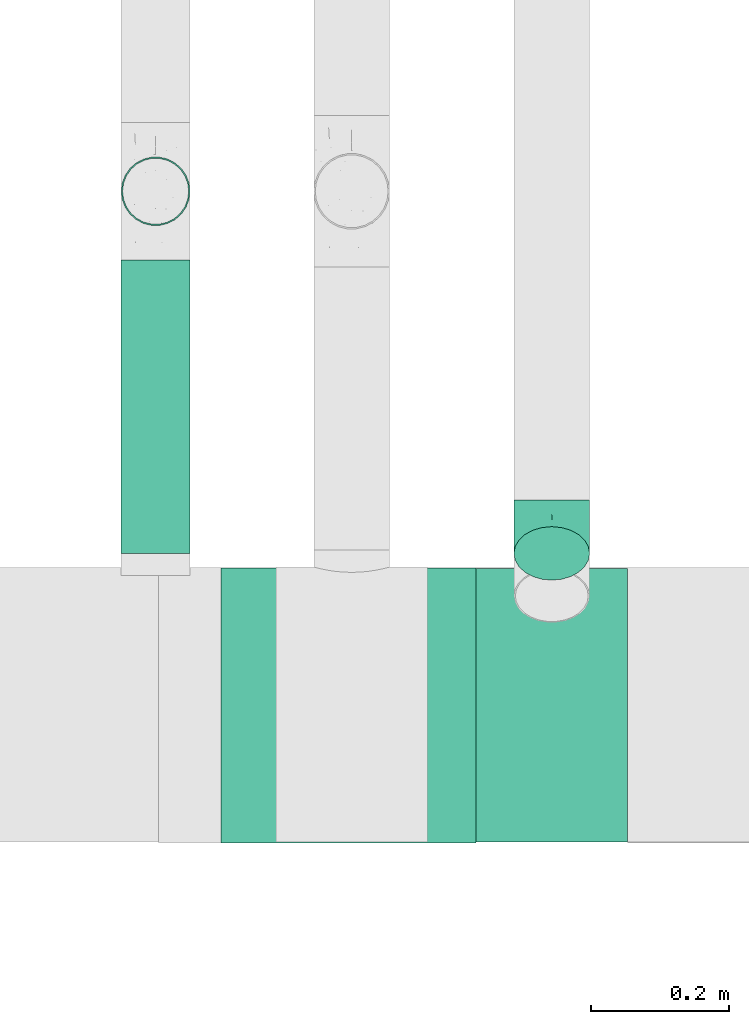
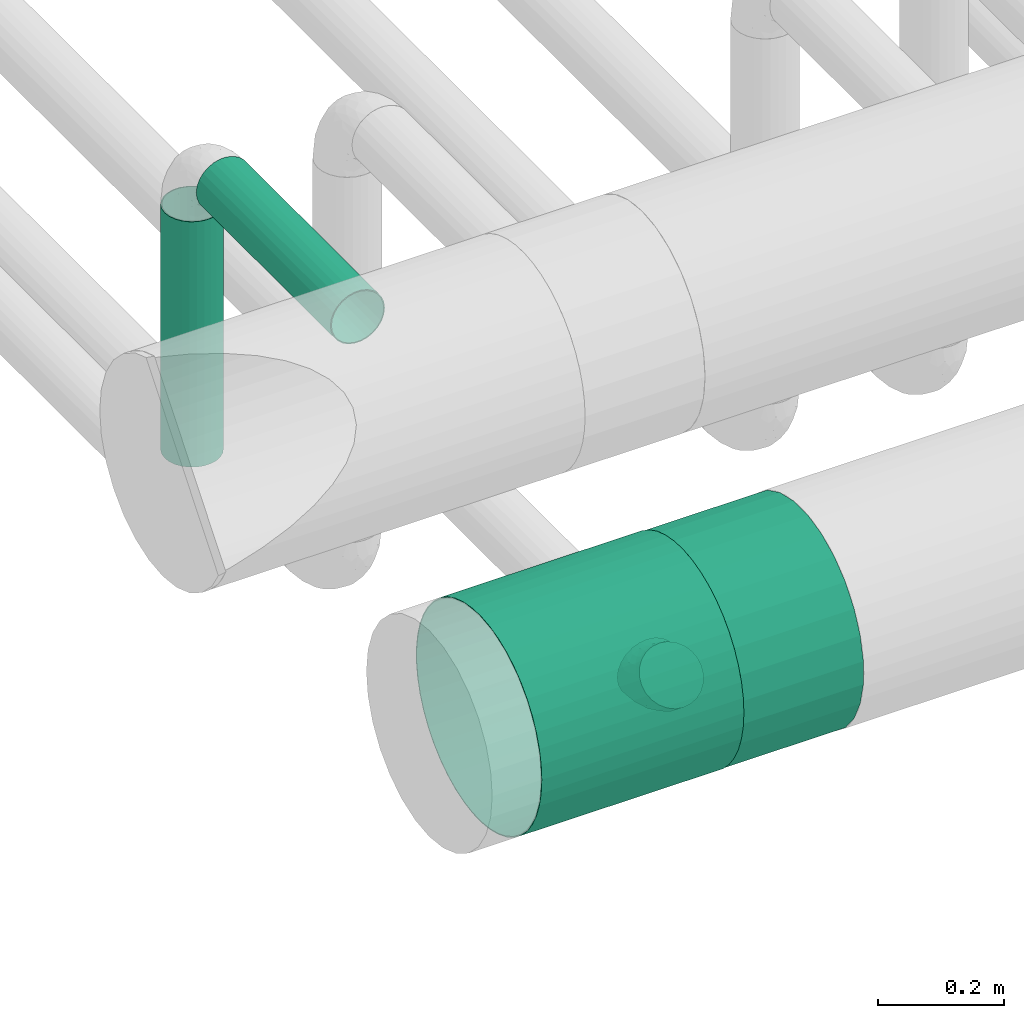
# One storey, part 74 of 91: 3 flow segments, 2 flow fittings.
"""IFC2X3 building model written with IfcOpenShell, lengths in millimetres."""

from ifc_helpers import new_model, entity, si_unit, converted_unit, derived_unit, direction, frame, origin_with_axes, origin_2d_with_axis, place, context, subcontext, project, spatial, hollow_circle, extrude, open_shell, surface_model, source, transform, mapped, material, layer, layer_set, layer_usage, type_object, element, save


model = new_model("IFC2X3")

# Units and contexts
model_context = context("Model", 3, precision=1e-05, world=origin_with_axes(), true_north=direction((0.0, 1.0)))
body_context = subcontext(model_context, "Body", "Model", "MODEL_VIEW")
ifc_project = project(units=[si_unit("AREAUNIT", "SQUARE_METRE"), si_unit("VOLUMEUNIT", "CUBIC_METRE", prefix="DECI"), si_unit("TIMEUNIT", "SECOND"), si_unit("THERMODYNAMICTEMPERATUREUNIT", "DEGREE_CELSIUS"), si_unit("PRESSUREUNIT", "PASCAL"), si_unit("MASSUNIT", "GRAM", prefix="KILO"), si_unit("LENGTHUNIT", "METRE", prefix="MILLI"), si_unit("POWERUNIT", "WATT"), si_unit("ELECTRICCURRENTUNIT", "AMPERE"), si_unit("ELECTRICVOLTAGEUNIT", "VOLT"), derived_unit("VOLUMETRICFLOWRATEUNIT", [(si_unit("VOLUMEUNIT", "CUBIC_METRE", prefix="DECI"), 1), (si_unit("TIMEUNIT", "SECOND"), -1)]), derived_unit("LINEARVELOCITYUNIT", [(si_unit("LENGTHUNIT", "METRE"), 1), (si_unit("TIMEUNIT", "SECOND"), -1)]), derived_unit("MASSDENSITYUNIT", [(si_unit("MASSUNIT", "GRAM", prefix="KILO"), 1), (si_unit("VOLUMEUNIT", "CUBIC_METRE"), -1)]), converted_unit("PLANEANGLEUNIT", "DEGREE", entity("IfcRatioMeasure", 0.01745), si_unit("PLANEANGLEUNIT", "RADIAN"), dimensions=[0, 0, 0, 0, 0, 0, 0])], contexts=[model_context])

# Site, building, storey
site_placement = place(None, origin_with_axes())
site = spatial("IfcSite", under=ifc_project, at=site_placement, CompositionType="ELEMENT")
building_placement = place(site_placement, origin_with_axes())
building = spatial("IfcBuilding", under=site, at=building_placement, Name="mc-building", CompositionType="ELEMENT")
storey_placement = place(building_placement, frame((0.0, 0.0, 8700.0), z_axis=(0.0, 0.0, 1.0), x_axis=(1.0, 0.0, 0.0)))
storey = spatial("IfcBuildingStorey", under=building, at=storey_placement, CompositionType="ELEMENT", Elevation=8700.0)

# Flow fittings
duct_fitting_type_1 = type_object("IfcDuctFittingType", PredefinedType="JUNCTION")
shared_shape_1 = source(origin_with_axes(), body_context, "Body", "SurfaceModel", [
    surface_model("IfcShellBasedSurfaceModel", [(0.0, -225.0, -55.0), (14.23505, -225.0, -53.12592), (-14.23505, -225.0, -53.12592), (-53.12592, -225.0, 14.23505), (-27.5, -225.0, -47.63139), (-47.63139, -225.0, -27.5), (-38.89087, -225.0, -38.89087), (55.0, -225.0, 0.0), (53.12592, -225.0, 14.23505), (38.89087, -225.0, -38.89087), (27.5, -225.0, -47.63139), (53.12592, -225.0, -14.23505), (47.63139, -225.0, -27.5), (-53.12592, -225.0, -14.23505), (-47.63139, -225.0, 27.5), (-38.89087, -225.0, 38.89087), (14.23505, -225.0, 53.12592), (-27.5, -225.0, 47.63139), (-14.23505, -225.0, 53.12592), (47.63139, -225.0, 27.5), (38.89087, -225.0, 38.89087), (27.5, -225.0, 47.63139), (0.0, -225.0, 55.0), (-55.0, -225.0, 0.0), (0.0, -192.28884, 55.0), (-12.29394, -192.68144, 53.60839), (-23.92751, -193.77184, 49.52246), (-34.31923, -195.32745, 42.97895), (-42.9874, -197.03532, 34.30865), (-49.52973, -198.56533, 23.91246), (-53.61252, -199.6229, 12.27592), (-55.0, -200.0, 0.0), (-49.52091, -198.56313, -23.93071), (-42.97449, -197.0325, -34.32482), (-53.60826, -199.62175, -12.29447), (-34.30293, -195.32458, -42.99196), (-23.90904, -193.76957, -49.53138), (-12.27509, -192.68024, -53.61271), (0.0, -192.28884, -55.0), (12.29394, -192.68144, -53.60839), (23.92751, -193.77184, -49.52246), (34.31923, -195.32745, -42.97895), (42.9874, -197.03532, -34.30865), (49.52973, -198.56533, -23.91246), (53.61252, -199.6229, -12.27592), (55.0, -200.0, 0.0), (49.52973, -198.56533, 23.91246), (42.9874, -197.03532, 34.30865), (53.61252, -199.6229, 12.27592), (34.31923, -195.32745, 42.97895), (23.92751, -193.77184, 49.52246), (12.29394, -192.68144, 53.60839), (-110.0, 0.0, -200.0), (-110.0, -44.50419, -194.98559), (-110.0, 44.50419, -194.98559), (-110.0, 194.98559, 44.50419), (-110.0, 86.77674, -180.19378), (-110.0, 180.19378, -86.77674), (-110.0, 156.36629, -124.69796), (-110.0, 124.69796, -156.36629), (-110.0, -200.0, 0.0), (-110.0, -194.98559, 44.50419), (-110.0, -124.69796, -156.36629), (-110.0, -86.77674, -180.19378), (-110.0, -156.36629, -124.69796), (-110.0, -180.19378, -86.77674), (-110.0, -194.98559, -44.50419), (-110.0, 194.98559, -44.50419), (-110.0, 180.19378, 86.77674), (-110.0, 156.36629, 124.69796), (-110.0, 86.77674, 180.19378), (-110.0, 124.69796, 156.36629), (-110.0, 44.50419, 194.98559), (-110.0, 0.0, 200.0), (-110.0, -156.36629, 124.69796), (-110.0, -180.19378, 86.77674), (-110.0, -86.77674, 180.19378), (-110.0, -44.50419, 194.98559), (-110.0, -124.69796, 156.36629), (-110.0, 200.0, 0.0), (110.0, 0.0, -200.0), (110.0, 44.50419, -194.98559), (110.0, 86.77674, -180.19378), (110.0, 200.0, 0.0), (110.0, 156.36629, -124.69796), (110.0, 180.19378, -86.77674), (110.0, 124.69796, -156.36629), (110.0, -156.36629, -124.69796), (110.0, -194.98559, 44.50419), (110.0, -86.77674, -180.19378), (110.0, -44.50419, -194.98559), (110.0, -124.69796, -156.36629), (110.0, -180.19378, -86.77674), (110.0, -194.98559, -44.50419), (110.0, -200.0, 0.0), (110.0, 194.98559, -44.50419), (110.0, 194.98559, 44.50419), (110.0, 180.19378, 86.77674), (110.0, 156.36629, 124.69796), (110.0, 124.69796, 156.36629), (110.0, 86.77674, 180.19378), (110.0, 44.50419, 194.98559), (110.0, -156.36629, 124.69796), (110.0, -180.19378, 86.77674), (110.0, -124.69796, 156.36629), (110.0, -86.77674, 180.19378), (110.0, -44.50419, 194.98559), (110.0, 0.0, 200.0), (-110.0, -197.4928, -22.25209), (110.0, -197.4928, -22.25209), (110.0, -197.4928, 22.25209), (-110.0, -197.4928, 22.25209)], [open_shell([[[0, 1, 2]], [[2, 3, 4]], [[5, 6, 3]], [[6, 4, 3]], [[2, 7, 8]], [[9, 7, 10]], [[1, 10, 7]], [[11, 7, 12]], [[9, 12, 7]], [[7, 2, 1]], [[5, 3, 13]], [[2, 14, 3]], [[2, 15, 14]], [[2, 16, 17]], [[17, 15, 2]], [[16, 18, 17]], [[2, 8, 19]], [[2, 19, 20]], [[2, 20, 21]], [[16, 2, 21]], [[16, 22, 18]], [[23, 13, 3]], [[22, 24, 25]], [[18, 25, 26]], [[22, 25, 18]], [[17, 27, 15]], [[17, 18, 26]], [[27, 17, 26]], [[28, 29, 14]], [[30, 31, 23]], [[29, 30, 3]], [[15, 28, 14]], [[3, 14, 29]], [[23, 3, 30]], [[28, 15, 27]], [[32, 33, 5]], [[34, 32, 13]], [[31, 34, 23]], [[23, 34, 13]], [[32, 5, 13]], [[33, 6, 5]], [[4, 35, 36]], [[36, 37, 2]], [[38, 0, 37]], [[4, 6, 35]], [[2, 4, 36]], [[37, 0, 2]], [[35, 6, 33]], [[0, 38, 39]], [[1, 39, 40]], [[0, 39, 1]], [[10, 41, 9]], [[10, 1, 40]], [[41, 10, 40]], [[42, 43, 12]], [[44, 45, 7]], [[43, 44, 11]], [[9, 42, 12]], [[11, 12, 43]], [[7, 11, 44]], [[42, 9, 41]], [[46, 47, 19]], [[48, 46, 8]], [[45, 48, 7]], [[7, 48, 8]], [[46, 19, 8]], [[47, 20, 19]], [[21, 49, 50]], [[50, 51, 16]], [[24, 22, 51]], [[20, 49, 21]], [[16, 21, 50]], [[22, 16, 51]], [[49, 20, 47]], [[52, 53, 54]], [[54, 55, 56]], [[55, 57, 58]], [[58, 59, 55]], [[59, 56, 55]], [[54, 60, 61]], [[62, 60, 63]], [[54, 53, 63]], [[60, 64, 65]], [[65, 66, 60]], [[60, 62, 64]], [[63, 60, 54]], [[55, 67, 57]], [[54, 68, 55]], [[54, 69, 68]], [[70, 71, 69]], [[70, 54, 72]], [[70, 69, 54]], [[72, 54, 73]], [[74, 73, 75]], [[54, 61, 75]], [[76, 77, 73]], [[73, 78, 76]], [[74, 78, 73]], [[54, 75, 73]], [[79, 67, 55]], [[80, 81, 82]], [[83, 80, 82]], [[84, 85, 83]], [[83, 86, 84]], [[83, 82, 86]], [[87, 80, 88]], [[80, 89, 90]], [[80, 91, 89]], [[91, 80, 87]], [[87, 88, 92]], [[93, 92, 88]], [[93, 88, 94]], [[85, 95, 83]], [[83, 96, 97]], [[98, 80, 97]], [[98, 99, 100]], [[80, 100, 101]], [[80, 98, 100]], [[80, 101, 102]], [[102, 103, 80]], [[88, 80, 103]], [[104, 102, 101]], [[104, 101, 105]], [[101, 106, 105]], [[101, 107, 106]], [[83, 97, 80]], [[72, 107, 101]], [[70, 101, 100]], [[71, 100, 99]], [[73, 107, 72]], [[72, 101, 70]], [[100, 71, 70]], [[99, 69, 71]], [[68, 98, 97]], [[55, 97, 96]], [[79, 96, 83]], [[69, 98, 68]], [[68, 97, 55]], [[96, 79, 55]], [[98, 69, 99]], [[83, 95, 79]], [[85, 84, 58]], [[95, 85, 67]], [[67, 79, 95]], [[58, 57, 85]], [[67, 85, 57]], [[84, 59, 58]], [[56, 86, 82]], [[54, 82, 81]], [[52, 81, 80]], [[59, 86, 56]], [[56, 82, 54]], [[81, 52, 54]], [[86, 59, 84]], [[90, 53, 80]], [[89, 63, 90]], [[65, 87, 92]], [[89, 91, 62]], [[87, 64, 91]], [[92, 40, 39]], [[39, 38, 92]], [[53, 90, 63]], [[62, 63, 89]], [[53, 52, 80]], [[38, 37, 65]], [[34, 108, 32]], [[64, 87, 65]], [[37, 36, 65]], [[64, 62, 91]], [[38, 65, 92]], [[42, 109, 43]], [[93, 42, 41]], [[93, 109, 42]], [[41, 40, 93]], [[93, 40, 92]], [[94, 45, 44]], [[43, 109, 44]], [[44, 109, 94]], [[36, 35, 66]], [[33, 32, 108]], [[33, 66, 35]], [[36, 66, 65]], [[34, 60, 108]], [[31, 60, 34]], [[108, 66, 33]], [[45, 94, 48]], [[94, 110, 48]], [[110, 47, 46]], [[47, 110, 88]], [[49, 47, 88]], [[29, 111, 30]], [[60, 31, 30]], [[111, 60, 30]], [[27, 26, 61]], [[61, 111, 28]], [[61, 28, 27]], [[26, 75, 61]], [[49, 88, 50]], [[51, 103, 24]], [[48, 110, 46]], [[51, 50, 103]], [[74, 103, 102]], [[103, 50, 88]], [[105, 106, 77]], [[76, 104, 105]], [[78, 102, 104]], [[73, 106, 107]], [[25, 24, 75]], [[28, 111, 29]], [[75, 24, 103]], [[74, 75, 103]], [[25, 75, 26]], [[102, 78, 74]], [[104, 76, 78]], [[77, 76, 105]], [[106, 73, 77]]])]),
])
flow_fitting_1_placement = place(storey_placement, frame((29888.82784, 10080.05037, 668.0), z_axis=(0.0, 0.707107, 0.707107), x_axis=(-1.0, 0.0, 0.0)))
element("IfcFlowFitting", 1, at=flow_fitting_1_placement, inside=storey, type_object=duct_fitting_type_1, context=body_context, shape_type="MappedRepresentation", body=[
    mapped(shared_shape_1, transform((0.0, 0.0, 0.0), scale=1.0)),
])
duct_fitting_type_2 = type_object("IfcDuctFittingType", Name="BU", PredefinedType="BEND")
shared_shape_2 = source(origin_with_axes(), body_context, "Body", "SurfaceModel", [
    surface_model("IfcShellBasedSurfaceModel", [(-45.56349, 0.0, -55.0), (-45.56349, -14.23505, -53.12592), (-45.56349, 14.23505, -53.12592), (-45.56349, 53.12592, 14.23505), (-45.56349, 27.5, -47.63139), (-45.56349, 38.89087, -38.89087), (-45.56349, 47.63139, -27.5), (-45.56349, -55.0, 0.0), (-45.56349, -53.12592, 14.23505), (-45.56349, -38.89087, -38.89087), (-45.56349, -27.5, -47.63139), (-45.56349, -53.12592, -14.23505), (-45.56349, -47.63139, -27.5), (-45.56349, 53.12592, -14.23505), (-45.56349, 47.63139, 27.5), (-45.56349, 38.89087, 38.89087), (-45.56349, -14.23505, 53.12592), (-45.56349, 27.5, 47.63139), (-45.56349, 14.23505, 53.12592), (-45.56349, -47.63139, 27.5), (-45.56349, -38.89087, 38.89087), (-45.56349, -27.5, 47.63139), (-45.56349, 0.0, 55.0), (-45.56349, 55.0, 0.0), (22.15256, 42.28395, -53.12592), (-6.67262, 71.10913, 0.0), (32.21826, 32.21826, -55.0), (12.77282, 51.66369, -47.63139), (-1.46223, 65.89874, -27.5), (4.71825, 59.71825, -38.89087), (59.71825, 4.71825, -38.89087), (69.78395, -5.34744, 14.23505), (51.66369, 12.77282, -47.63139), (42.28395, 22.15256, -53.12592), (65.89874, -1.46223, -27.5), (69.78395, -5.34744, -14.23505), (71.10913, -6.67262, 0.0), (-5.34744, 69.78395, -14.23505), (-5.34744, 69.78395, 14.23505), (-1.46223, 65.89874, 27.5), (4.71825, 59.71825, 38.89087), (32.21826, 32.21826, 55.0), (12.77282, 51.66369, 47.63139), (22.15256, 42.28395, 53.12592), (59.71825, 4.71825, 38.89087), (65.89874, -1.46223, 27.5), (42.28395, 22.15256, 53.12592), (51.66369, 12.77282, 47.63139), (-20.16649, 48.68621, 33.48188), (-26.97111, 35.77503, 43.63444), (-7.30443, 43.73336, 43.63444), (-17.0934, 3.74816, 55.0), (-18.00408, 15.44793, 53.78143), (-30.11707, 22.39897, 50.81337), (-7.49776, 55.63651, 33.48188), (-15.97018, 58.74288, 21.04759), (-31.18231, 52.58712, 21.04759), (-18.35174, 61.03934, 10.51509), (-28.67677, 56.60048, 10.47121), (-34.03924, 44.64267, 33.48188), (-11.52288, 27.81868, 50.81338), (1.19951, 23.16465, 53.81115), (-33.77926, 57.34403, 0.0), (5.4586, 37.12132, 50.81809), (-24.5159, 59.18663, 0.0), (-16.66281, 64.4339, 0.0), (9.43651, 14.73721, 55.0), (-6.22531, 44.36822, -43.63444), (5.4586, 37.12132, -50.81809), (-34.03924, 44.64267, -33.48188), (9.43651, 14.73721, -55.0), (-17.0934, 3.74816, -55.0), (1.19951, 23.16465, -53.81115), (-11.52288, 27.81868, -50.81338), (-30.11707, 22.39897, -50.81337), (-25.75914, 36.08917, -43.63444), (-30.24487, 52.83011, -21.04759), (-20.16649, 48.68621, -33.48188), (-7.49776, 55.63651, -33.48188), (-18.00408, 15.44793, -53.78143), (-28.68366, 56.62226, -10.35271), (-14.15883, 63.53074, -10.87592), (-15.13548, 59.23394, -21.04759), (3.19797, -7.72059, -52.16847), (3.1272, -18.04126, -47.9241), (13.63233, -32.91136, -32.06475), (45.23618, -22.99734, -20.4997), (16.67434, -40.25541, -15.9539), (-17.3935, -51.68264, -9.80849), (-2.85835, -49.37776, 0.0), (48.84421, -24.24609, -9.80849), (-16.38424, -42.76862, -30.85433), (-6.97383, -29.41689, -42.70541), (41.82739, -18.65658, -30.85433), (-15.72523, -48.24839, -20.4997), (29.28945, -13.63928, -42.80781), (26.81493, -3.56603, -49.15704), (36.93651, -32.89419, 0.0), (-15.72523, -48.24839, 20.4997), (-17.3935, -51.68264, 9.80849), (-16.38424, -42.76862, 30.85433), (16.67434, -40.25541, 15.9539), (3.19797, -7.72059, 52.16847), (10.54583, -14.96836, 47.9241), (13.63233, -32.91136, 32.06475), (45.23618, -22.99734, 20.4997), (41.82739, -18.65658, 30.85433), (-11.06635, -30.3552, 42.80781), (25.73213, -15.86964, 42.70541), (-16.43945, -21.48258, 49.15704), (48.84421, -24.24609, 9.80849)], [open_shell([[[0, 1, 2]], [[2, 3, 4]], [[5, 3, 6]], [[4, 3, 5]], [[2, 7, 8]], [[9, 7, 10]], [[1, 10, 7]], [[11, 7, 12]], [[9, 12, 7]], [[7, 2, 1]], [[13, 6, 3]], [[14, 3, 2]], [[15, 14, 2]], [[16, 17, 2]], [[2, 17, 15]], [[16, 18, 17]], [[19, 20, 2]], [[19, 2, 8]], [[20, 21, 2]], [[2, 21, 16]], [[16, 22, 18]], [[23, 13, 3]], [[24, 25, 26]], [[27, 25, 24]], [[28, 25, 29]], [[29, 25, 27]], [[30, 26, 31]], [[26, 30, 32]], [[32, 33, 26]], [[34, 31, 35]], [[31, 34, 30]], [[35, 31, 36]], [[37, 25, 28]], [[26, 38, 39]], [[26, 39, 40]], [[41, 40, 42]], [[26, 40, 41]], [[42, 43, 41]], [[26, 44, 45]], [[31, 26, 45]], [[46, 47, 26]], [[47, 44, 26]], [[46, 26, 41]], [[26, 25, 38]], [[48, 49, 50]], [[22, 51, 52]], [[17, 49, 15]], [[53, 17, 18]], [[49, 17, 53]], [[54, 50, 40]], [[48, 55, 56]], [[55, 57, 58]], [[59, 14, 15]], [[60, 53, 52]], [[50, 49, 60]], [[58, 3, 56]], [[52, 51, 61]], [[62, 23, 3]], [[63, 50, 60]], [[50, 42, 40]], [[3, 58, 62]], [[43, 61, 41]], [[62, 58, 64]], [[48, 59, 49]], [[14, 56, 3]], [[40, 39, 54]], [[57, 64, 58]], [[39, 38, 55]], [[63, 60, 61]], [[54, 55, 48]], [[65, 57, 38]], [[56, 14, 59]], [[38, 25, 65]], [[60, 52, 61]], [[49, 59, 15]], [[55, 58, 56]], [[56, 59, 48]], [[55, 54, 39]], [[50, 54, 48]], [[18, 22, 52]], [[49, 53, 60]], [[18, 52, 53]], [[61, 51, 66]], [[41, 61, 66]], [[63, 61, 43]], [[43, 42, 63]], [[50, 63, 42]], [[38, 57, 55]], [[64, 57, 65]], [[67, 27, 68]], [[69, 5, 6]], [[70, 71, 72]], [[73, 74, 75]], [[76, 77, 69]], [[29, 78, 28]], [[2, 79, 0]], [[13, 23, 62]], [[2, 74, 79]], [[5, 75, 4]], [[77, 78, 67]], [[13, 62, 80]], [[64, 80, 62]], [[81, 80, 64]], [[67, 73, 75]], [[82, 77, 76]], [[81, 64, 65]], [[76, 69, 6]], [[82, 76, 80]], [[24, 72, 68]], [[74, 2, 4]], [[27, 67, 29]], [[26, 70, 72]], [[69, 75, 5]], [[82, 28, 78]], [[72, 71, 79]], [[6, 13, 76]], [[77, 67, 75]], [[13, 80, 76]], [[82, 37, 28]], [[81, 25, 37]], [[82, 81, 37]], [[75, 69, 77]], [[67, 78, 29]], [[82, 78, 77]], [[75, 74, 4]], [[79, 74, 73]], [[79, 73, 72]], [[79, 71, 0]], [[68, 72, 73]], [[26, 72, 24]], [[67, 68, 73]], [[27, 24, 68]], [[80, 81, 82]], [[25, 81, 65]], [[1, 83, 84]], [[85, 86, 87]], [[0, 71, 1]], [[88, 87, 89]], [[90, 86, 35]], [[91, 92, 85]], [[11, 88, 7]], [[30, 34, 93]], [[11, 12, 94]], [[92, 91, 9]], [[85, 94, 91]], [[94, 85, 87]], [[95, 93, 85]], [[85, 92, 95]], [[83, 71, 70]], [[12, 9, 91]], [[70, 26, 33]], [[96, 84, 83]], [[1, 71, 83]], [[95, 96, 32]], [[95, 30, 93]], [[95, 32, 30]], [[97, 89, 87]], [[34, 86, 93]], [[36, 97, 90]], [[94, 88, 11]], [[34, 35, 86]], [[90, 87, 86]], [[93, 86, 85]], [[32, 96, 33]], [[84, 10, 1]], [[33, 83, 70]], [[94, 12, 91]], [[10, 92, 9]], [[87, 88, 94]], [[7, 88, 89]], [[36, 90, 35]], [[87, 90, 97]], [[84, 95, 92]], [[33, 96, 83]], [[95, 84, 96]], [[10, 84, 92]], [[8, 98, 19]], [[7, 89, 99]], [[19, 98, 100]], [[101, 98, 99]], [[46, 102, 103]], [[104, 105, 106]], [[100, 98, 104]], [[107, 104, 108]], [[16, 51, 22]], [[51, 16, 102]], [[107, 20, 100]], [[107, 109, 21]], [[21, 20, 107]], [[103, 47, 46]], [[101, 89, 97]], [[105, 110, 31]], [[44, 47, 108]], [[105, 104, 101]], [[107, 100, 104]], [[31, 110, 36]], [[109, 16, 21]], [[108, 106, 44]], [[105, 45, 106]], [[41, 66, 46]], [[102, 66, 51]], [[46, 66, 102]], [[104, 98, 101]], [[99, 98, 8]], [[106, 108, 104]], [[110, 101, 97]], [[45, 44, 106]], [[105, 31, 45]], [[20, 19, 100]], [[109, 103, 102]], [[101, 110, 105]], [[36, 110, 97]], [[7, 99, 8]], [[101, 99, 89]], [[103, 107, 108]], [[16, 109, 102]], [[107, 103, 109]], [[47, 103, 108]]])]),
])
flow_fitting_2_placement = place(storey_placement, frame((29888.82784, 10333.05037, 415.0), z_axis=(-1.0, 0.0, 0.0), x_axis=(0.0, -1.0, 0.0)))
element("IfcFlowFitting", 2, at=flow_fitting_2_placement, inside=storey, type_object=duct_fitting_type_2, Name="BU", context=body_context, shape_type="MappedRepresentation", body=[
    mapped(shared_shape_2, transform((0.0, 0.0, 0.0), scale=1.0)),
])

# Flow segments
ifc_material = material(Name="FZ1")
ifc_layer = layer(ifc_material, 0.0)
ifc_layer_set = layer_set([ifc_layer], Name="FZ1")
ifc_layer_usage = layer_usage(ifc_layer_set, "AXIS1", "POSITIVE", 0.0)
duct_segment_type_1 = type_object("IfcDuctSegmentType", PredefinedType="RIGIDSEGMENT")
shared_shape_3 = source(origin_with_axes(), body_context, "Body", "SweptSolid", [
    extrude(hollow_circle(Radius=50.0, WallThickness=2.0, at=origin_2d_with_axis()), frame((0.0, 0.0, 0.0), z_axis=(1.0, 0.0, 0.0), x_axis=(0.0, 1.0, 0.0)), (0.0, 0.0, 1.0), 476.0),
])
flow_segment_1_placement = place(storey_placement, frame((29312.94843, 10827.25695, 1244.0), z_axis=(0.0, 1.0, 0.0), x_axis=(0.0, 0.0, -1.0)))
element("IfcFlowSegment", 3, at=flow_segment_1_placement, inside=storey, type_object=duct_segment_type_1, material=ifc_layer_usage, context=body_context, shape_type="MappedRepresentation", body=[
    mapped(shared_shape_3, transform((0.0, 0.0, 0.0), scale=1.0)),
])
duct_segment_type_2 = type_object("IfcDuctSegmentType", Name="Safe", PredefinedType="RIGIDSEGMENT")
shared_shape_4 = source(origin_with_axes(), body_context, "Body", "SweptSolid", [
    extrude(hollow_circle(Radius=200.0, WallThickness=2.0, at=origin_2d_with_axis()), frame((0.0, 0.0, 0.0), z_axis=(1.0, 0.0, 0.0), x_axis=(0.0, 1.0, 0.0)), (0.0, 0.0, 1.0), 370.9),
])
flow_segment_2_placement = place(storey_placement, frame((29778.82784, 10080.05037, 668.0), z_axis=(0.0, 0.0, 1.0), x_axis=(-1.0, 0.0, 0.0)))
element("IfcFlowSegment", 4, at=flow_segment_2_placement, inside=storey, type_object=duct_segment_type_2, material=ifc_layer_usage, Name="Safe", context=body_context, shape_type="MappedRepresentation", body=[
    mapped(shared_shape_4, transform((0.0, 0.0, 0.0), scale=1.0)),
])
shared_shape_5 = source(origin_with_axes(), body_context, "Body", "SweptSolid", [
    extrude(hollow_circle(Radius=50.0, WallThickness=2.0, at=origin_2d_with_axis()), frame((0.0, 0.0, 0.0), z_axis=(1.0, 0.0, 0.0), x_axis=(0.0, 1.0, 0.0)), (0.0, 0.0, 1.0), 426.3),
])
flow_segment_3_placement = place(storey_placement, frame((29312.94843, 10300.96985, 1344.0), z_axis=(0.0, 0.0, 1.0), x_axis=(0.0, 1.0, 0.0)))
element("IfcFlowSegment", 5, at=flow_segment_3_placement, inside=storey, type_object=duct_segment_type_1, material=ifc_layer_usage, context=body_context, shape_type="MappedRepresentation", body=[
    mapped(shared_shape_5, transform((0.0, 0.0, 0.0), scale=1.0)),
])

save(model, "model.ifc")
